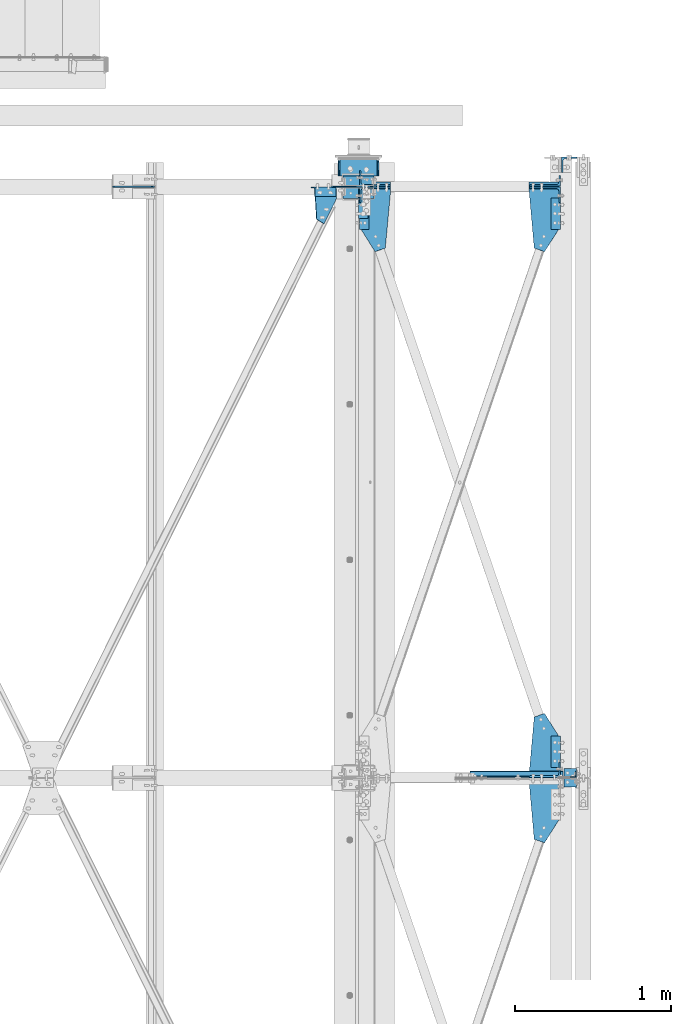
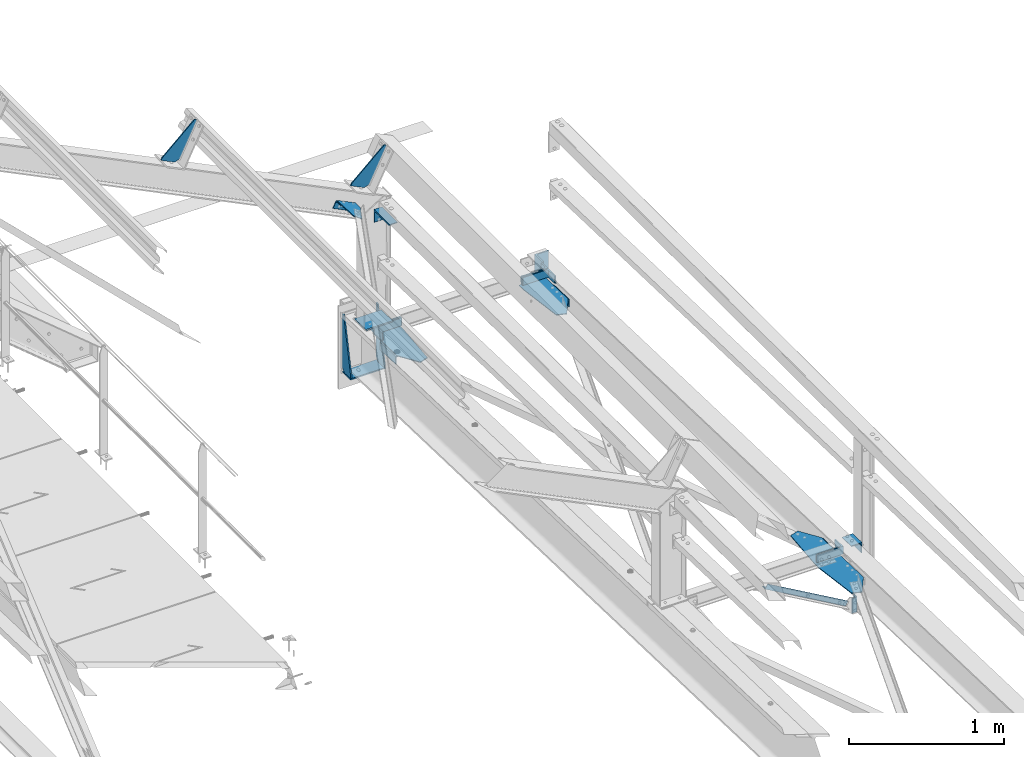
# One storey, part 112 of 496: 17 beams, 7 members, 22 elements without a shape of their own.
"""IFC2X3 building model written with IfcOpenShell, lengths in millimetres."""

from ifc_helpers import new_model, si_unit, frame, origin_with_axes, origin_2d_with_axis, place, context, subcontext, project, spatial, polyline, rectangle, l_section, outline, extrude, clip, halfspace, material, type_object, element, aggregate, save


model = new_model("IFC2X3")

# Units and contexts
model_context = context("Model", 3, precision=1e-05, world=origin_with_axes())
body_context = subcontext(model_context, "Body", "Model", "MODEL_VIEW")
ifc_project = project(units=[si_unit("LENGTHUNIT", "METRE", prefix="MILLI"), si_unit("AREAUNIT", "SQUARE_METRE"), si_unit("VOLUMEUNIT", "CUBIC_METRE"), si_unit("MASSUNIT", "GRAM", prefix="KILO"), si_unit("TIMEUNIT", "SECOND"), si_unit("PLANEANGLEUNIT", "RADIAN"), si_unit("SOLIDANGLEUNIT", "STERADIAN"), si_unit("THERMODYNAMICTEMPERATUREUNIT", "DEGREE_CELSIUS"), si_unit("LUMINOUSINTENSITYUNIT", "LUMEN")], contexts=[model_context])

# Site, building, storey
site_placement = place(None, origin_with_axes())
site = spatial("IfcSite", under=ifc_project, at=site_placement, CompositionType="ELEMENT")
building_placement = place(site_placement, origin_with_axes())
building = spatial("IfcBuilding", under=site, at=building_placement, Name="Undefined", CompositionType="ELEMENT")
storey_placement = place(building_placement, origin_with_axes())
storey = spatial("IfcBuildingStorey", under=building, at=storey_placement, Name="Undefined", CompositionType="ELEMENT", Elevation=0.0)

# Assembly, beam
assembly_1_placement = place(storey_placement, origin_with_axes())
assembly_1 = element("IfcElementAssembly", 1, at=assembly_1_placement, inside=storey, AssemblyPlace="NOTDEFINED", PredefinedType="NOTDEFINED")
ifc_material = material(Name="Undefined/S235-E24")
beam_type_1 = type_object("IfcBeamType", PredefinedType="NOTDEFINED")
beam_1_placement = place(assembly_1_placement, frame((39596.4999999987, 11466.9500236267, 7533.55960076532), z_axis=(0.0, -0.031410887010906, -0.999506556345274), x_axis=(0.0, 0.999506556345274, -0.0314108870109058)))
beam_1 = element("IfcBeam", 2, at=beam_1_placement, type_object=beam_type_1, material=ifc_material, context=body_context, shape_type="SweptSolid", body=[
    extrude(l_section(Depth=60.0, Width=60.0, Thickness=6.0, FilletRadius=8.0, EdgeRadius=4.0, at=origin_2d_with_axis()), frame((200.0, 0.0, 0.0), z_axis=(-1.0, 0.0, 0.0), x_axis=(0.0, -1.0, 0.0)), (0.0, 0.0, 1.0), 200.0),
])
aggregate(assembly_1, [beam_1])

assembly_2_placement = place(storey_placement, origin_with_axes())
assembly_2 = element("IfcElementAssembly", 3, at=assembly_2_placement, inside=storey, AssemblyPlace="NOTDEFINED", PredefinedType="NOTDEFINED")
beam_2_placement = place(assembly_2_placement, frame((39596.4999999987, 14925.2331446423, 7424.8786388297), z_axis=(0.0, -0.031410887010906, -0.999506556345274), x_axis=(0.0, 0.999506556345274, -0.0314108870109058)))
beam_2 = element("IfcBeam", 4, at=beam_2_placement, type_object=beam_type_1, material=ifc_material, context=body_context, shape_type="SweptSolid", body=[
    extrude(l_section(Depth=60.0, Width=60.0, Thickness=6.0, FilletRadius=8.0, EdgeRadius=4.0, at=origin_2d_with_axis()), frame((200.0, 0.0, 0.0), z_axis=(-1.0, 0.0, 0.0), x_axis=(0.0, -1.0, 0.0)), (0.0, 0.0, 1.0), 200.0),
])
aggregate(assembly_2, [beam_2])

assembly_3_placement = place(storey_placement, origin_with_axes())
assembly_3 = element("IfcElementAssembly", 5, at=assembly_3_placement, inside=storey, AssemblyPlace="NOTDEFINED", PredefinedType="NOTDEFINED")
beam_3_placement = place(assembly_3_placement, frame((38365.0000000024, 15125.1344555687, 7418.59645027728), z_axis=(0.0, -0.031410887010906, -0.999506556345274), x_axis=(0.0, -0.999506556345276, 0.031410887010852)))
beam_3 = element("IfcBeam", 6, at=beam_3_placement, type_object=beam_type_1, material=ifc_material, context=body_context, shape_type="SweptSolid", body=[
    extrude(l_section(Depth=60.0, Width=60.0, Thickness=6.0, FilletRadius=8.0, EdgeRadius=4.0, at=origin_2d_with_axis()), frame((200.0, 0.0, 0.0), z_axis=(-1.0, 0.0, 0.0), x_axis=(0.0, -1.0, 0.0)), (0.0, 0.0, 1.0), 200.0),
])
aggregate(assembly_3, [beam_3])

assembly_4_placement = place(storey_placement, origin_with_axes())
assembly_4 = element("IfcElementAssembly", 7, at=assembly_4_placement, inside=storey, Name="TRAVERSE SHED", AssemblyPlace="NOTDEFINED", PredefinedType="NOTDEFINED")
beam_type_2 = type_object("IfcBeamType", PredefinedType="NOTDEFINED")
beam_4_placement = place(assembly_4_placement, frame((38330.0, 15274.8056218445, 7574.97237948849), z_axis=(-1.0, 0.0, 0.0), x_axis=(0.0, -0.999506556345276, 0.031410887010852)))
beam_4 = element("IfcBeam", 8, at=beam_4_placement, type_object=beam_type_2, material=ifc_material, context=body_context, shape_type="SweptSolid", body=[
    extrude(rectangle(XDim=10.0, YDim=200.0, at=origin_2d_with_axis()), frame((149.999995982835, 4.54747350886464e-12, 3.63797880709171e-12), z_axis=(-1.0, 0.0, 0.0), x_axis=(0.0, -1.0, 0.0)), (0.0, 0.0, 1.0), 150.0),
])
aggregate(assembly_4, [beam_4])

assembly_5_placement = place(storey_placement, origin_with_axes())
assembly_5 = element("IfcElementAssembly", 9, at=assembly_5_placement, inside=storey, AssemblyPlace="NOTDEFINED", PredefinedType="NOTDEFINED")
beam_type_3 = type_object("IfcBeamType", PredefinedType="NOTDEFINED")
beam_5_placement = place(assembly_5_placement, frame((39689.0, 11460.1274473956, 7639.62620400558), z_axis=(-1.0, 0.0, 0.0), x_axis=(0.0, -0.999506556345276, 0.031410887010852)))
beam_5 = element("IfcBeam", 10, at=beam_5_placement, type_object=beam_type_3, material=ifc_material, context=body_context, shape_type="SweptSolid", body=[
    extrude(l_section(Depth=80.0, Width=80.0, Thickness=8.0, FilletRadius=10.0, EdgeRadius=5.0, at=origin_2d_with_axis()), frame((120.0, 0.0, 0.0), z_axis=(-1.0, 0.0, 0.0), x_axis=(0.0, -1.0, 0.0)), (0.0, 0.0, 1.0), 120.0),
])
aggregate(assembly_5, [beam_5])

assembly_6_placement = place(storey_placement, origin_with_axes())
assembly_6 = element("IfcElementAssembly", 11, at=assembly_6_placement, inside=storey, AssemblyPlace="NOTDEFINED", PredefinedType="NOTDEFINED")
beam_type_4 = type_object("IfcBeamType", PredefinedType="NOTDEFINED")
beam_6_placement = place(assembly_6_placement, frame((39709.0000003665, 11422.9999999731, 7220.00000925125), z_axis=(-1.0, 0.0, 0.0), x_axis=(0.0, 0.0, -1.0)))
beam_6 = element("IfcBeam", 12, at=beam_6_placement, type_object=beam_type_4, material=ifc_material, context=body_context, shape_type="SweptSolid", body=[
    extrude(l_section(Depth=40.0, Width=40.0, Thickness=4.0, FilletRadius=6.0, EdgeRadius=3.0, at=origin_2d_with_axis()), frame((120.0, 0.0, 0.0), z_axis=(-1.0, 0.0, 0.0), x_axis=(0.0, -1.0, 0.0)), (0.0, 0.0, 1.0), 120.0),
])
aggregate(assembly_6, [beam_6])

# Assembly, member
assembly_7_placement = place(storey_placement, origin_with_axes())
assembly_7 = element("IfcElementAssembly", 13, at=assembly_7_placement, inside=storey, AssemblyPlace="NOTDEFINED", PredefinedType="NOTDEFINED")
member_type_1 = type_object("IfcMemberType", PredefinedType="NOTDEFINED")
member_1_placement = place(assembly_7_placement, frame((38035.9184902341, 15167.0004847153, 8592.20874332605), z_axis=(0.0, -1.0, 0.0), x_axis=(0.897398510539058, 0.0, -0.441220934773362)))
member_1 = element("IfcMember", 14, at=member_1_placement, type_object=member_type_1, material=ifc_material, context=body_context, shape_type="SweptSolid", body=[
    extrude(l_section(Depth=60.0, Width=60.0, Thickness=6.0, FilletRadius=8.0, EdgeRadius=4.0, at=origin_2d_with_axis()), frame((149.999995982835, 4.54747350886464e-12, 3.63797880709171e-12), z_axis=(-1.0, 0.0, 0.0), x_axis=(0.0, -1.0, 0.0)), (0.0, 0.0, 1.0), 150.0),
])
aggregate(assembly_7, [member_1])

# Assembly, beam
assembly_8_placement = place(storey_placement, origin_with_axes())
assembly_8 = element("IfcElementAssembly", 15, at=assembly_8_placement, inside=storey, Name="SHED", AssemblyPlace="NOTDEFINED", PredefinedType="NOTDEFINED")
beam_type_5 = type_object("IfcBeamType", PredefinedType="NOTDEFINED")
beam_7_placement = place(assembly_8_placement, frame((38167.3881652729, 15200.0, 8712.54750741415), z_axis=(0.0, -1.0, 0.0), x_axis=(-0.441220935974661, 0.0, -0.89739850994842)))
beam_7 = element("IfcBeam", 16, at=beam_7_placement, type_object=beam_type_5, material=ifc_material, context=body_context, shape_type="SweptSolid", body=[
    extrude(outline(polyline([(0.0, 0.0), (20.0, 0.0), (20.0000000002019, 109.999999999982), (-9.99999999974731, 139.99998998623), (-300.0000000002, 139.999893186625), (-300.000000000226, 119.999893186643), (0.0, 0.0)])), frame((0.0, 0.0, -4.0), z_axis=(0.0, 0.0, 1.0), x_axis=(1.0, 0.0, 0.0)), (0.0, 0.0, 1.0), 8.0),
])
aggregate(assembly_8, [beam_7])

assembly_9_placement = place(storey_placement, origin_with_axes())
assembly_9 = element("IfcElementAssembly", 17, at=assembly_9_placement, inside=storey, Name="SHED", AssemblyPlace="NOTDEFINED", PredefinedType="NOTDEFINED")
beam_8_placement = place(assembly_9_placement, frame((36758.937741054, 15200.0, 9405.03563331224), z_axis=(0.0, -1.0, 0.0), x_axis=(-0.441220935974661, 0.0, -0.89739850994842)))
beam_8 = element("IfcBeam", 18, at=beam_8_placement, type_object=beam_type_5, material=ifc_material, context=body_context, shape_type="SweptSolid", body=[
    extrude(outline(polyline([(0.0, 0.0), (20.0, 0.0), (20.0000000002019, 109.999999999982), (-9.99999999974731, 139.99998998623), (-300.0000000002, 139.999893186625), (-300.000000000226, 119.999893186643), (0.0, 0.0)])), frame((0.0, 0.0, -4.0), z_axis=(0.0, 0.0, 1.0), x_axis=(1.0, 0.0, 0.0)), (0.0, 0.0, 1.0), 8.0),
])
aggregate(assembly_9, [beam_8])

# Assembly, member
assembly_10_placement = place(storey_placement, origin_with_axes())
assembly_10 = element("IfcElementAssembly", 19, at=assembly_10_placement, inside=storey, AssemblyPlace="NOTDEFINED", PredefinedType="NOTDEFINED")
member_type_2 = type_object("IfcMemberType", PredefinedType="NOTDEFINED")
member_2_placement = place(assembly_10_placement, frame((39526.5, 15253.6029386135, 7530.61641099022), z_axis=(-1.0, 0.0, 0.0), x_axis=(0.0, -0.031410887010906, -0.999506556345274)))
member_2 = element("IfcMember", 20, at=member_2_placement, type_object=member_type_2, material=ifc_material, context=body_context, shape_type="Clipping", body=[
    clip(extrude(l_section(Depth=200.0, Width=100.0, Thickness=10.0, FilletRadius=15.0, EdgeRadius=7.5, at=origin_2d_with_axis()), frame((60.0, 0.0, 0.0), z_axis=(-1.0, 0.0, 0.0), x_axis=(0.0, -1.0, 0.0)), (0.0, 0.0, 1.0), 60.0), halfspace(frame((1.72803993336856e-11, -19.9999999480369, -100.0), z_axis=(0.0, -1.0, 0.0), x_axis=(0.0, 0.0, 1.0)), False)),
])
aggregate(assembly_10, [member_2])

assembly_11_placement = place(storey_placement, origin_with_axes())
assembly_11 = element("IfcElementAssembly", 21, at=assembly_11_placement, inside=storey, AssemblyPlace="NOTDEFINED", PredefinedType="NOTDEFINED")
member_3_placement = place(assembly_11_placement, frame((39526.4999999999, 15145.7696877701, 7473.97567400464), z_axis=(-1.0, 0.0, 0.0), x_axis=(0.0, 0.031410887010906, 0.999506556345274)))
member_3 = element("IfcMember", 22, at=member_3_placement, type_object=member_type_2, material=ifc_material, context=body_context, shape_type="SweptSolid", body=[
    extrude(l_section(Depth=200.0, Width=100.0, Thickness=10.0, FilletRadius=15.0, EdgeRadius=7.5, at=origin_2d_with_axis()), frame((60.0, 0.0, 0.0), z_axis=(-1.0, 0.0, 0.0), x_axis=(0.0, -1.0, 0.0)), (0.0, 0.0, 1.0), 60.0),
])
aggregate(assembly_11, [member_3])

assembly_12_placement = place(storey_placement, origin_with_axes())
assembly_12 = element("IfcElementAssembly", 23, at=assembly_12_placement, inside=storey, AssemblyPlace="NOTDEFINED", PredefinedType="NOTDEFINED")
member_4_placement = place(assembly_12_placement, frame((39526.5, 11453.6029378067, 7650.03622172562), z_axis=(-1.0, 0.0, 0.0), x_axis=(0.0, -0.031410887010906, -0.999506556345274)))
member_4 = element("IfcMember", 24, at=member_4_placement, type_object=member_type_2, material=ifc_material, context=body_context, shape_type="SweptSolid", body=[
    extrude(l_section(Depth=200.0, Width=100.0, Thickness=10.0, FilletRadius=15.0, EdgeRadius=7.5, at=origin_2d_with_axis()), frame((60.0, 0.0, 0.0), z_axis=(-1.0, 0.0, 0.0), x_axis=(0.0, -1.0, 0.0)), (0.0, 0.0, 1.0), 60.0),
])
aggregate(assembly_12, [member_4])

assembly_13_placement = place(storey_placement, origin_with_axes())
assembly_13 = element("IfcElementAssembly", 25, at=assembly_13_placement, inside=storey, AssemblyPlace="NOTDEFINED", PredefinedType="NOTDEFINED")
member_5_placement = place(assembly_13_placement, frame((38435.0, 15251.7182422282, 7470.64601896635), z_axis=(1.0, 0.0, 0.0), x_axis=(0.0, 0.031410887010906, 0.999506556345274)))
member_5 = element("IfcMember", 26, at=member_5_placement, type_object=member_type_2, material=ifc_material, context=body_context, shape_type="SweptSolid", body=[
    extrude(l_section(Depth=200.0, Width=100.0, Thickness=10.0, FilletRadius=15.0, EdgeRadius=7.5, at=origin_2d_with_axis()), frame((60.0, 0.0, 0.0), z_axis=(-1.0, 0.0, 0.0), x_axis=(0.0, -1.0, 0.0)), (0.0, 0.0, 1.0), 60.0),
])
aggregate(assembly_13, [member_5])

assembly_14_placement = place(storey_placement, origin_with_axes())
assembly_14 = element("IfcElementAssembly", 27, at=assembly_14_placement, inside=storey, AssemblyPlace="NOTDEFINED", PredefinedType="NOTDEFINED")
member_6_placement = place(assembly_14_placement, frame((38435.0000000001, 15147.6543841035, 7533.94606602883), z_axis=(1.0, 0.0, 0.0), x_axis=(0.0, -0.031410887010906, -0.999506556345274)))
member_6 = element("IfcMember", 28, at=member_6_placement, type_object=member_type_2, material=ifc_material, context=body_context, shape_type="SweptSolid", body=[
    extrude(l_section(Depth=200.0, Width=100.0, Thickness=10.0, FilletRadius=15.0, EdgeRadius=7.5, at=origin_2d_with_axis()), frame((60.0, 0.0, 0.0), z_axis=(-1.0, 0.0, 0.0), x_axis=(0.0, -1.0, 0.0)), (0.0, 0.0, 1.0), 60.0),
])
aggregate(assembly_14, [member_6])

# Assembly, beam
assembly_15_placement = place(storey_placement, origin_with_axes())
assembly_15 = element("IfcElementAssembly", 29, at=assembly_15_placement, inside=storey, AssemblyPlace="NOTDEFINED", PredefinedType="NOTDEFINED")
beam_type_6 = type_object("IfcBeamType", PredefinedType="NOTDEFINED")
beam_9_placement = place(assembly_15_placement, frame((38330.0, 15096.5, 8400.0), z_axis=(0.0, -1.0, 0.0), x_axis=(1.0, 0.0, 0.0)))
beam_9 = element("IfcBeam", 30, at=beam_9_placement, type_object=beam_type_6, material=ifc_material, context=body_context, shape_type="SweptSolid", body=[
    extrude(l_section(Depth=200.0, Width=100.0, Thickness=10.0, FilletRadius=15.0, EdgeRadius=7.5, at=origin_2d_with_axis()), frame((60.0, 0.0, 0.0), z_axis=(-1.0, 0.0, 0.0), x_axis=(0.0, -1.0, 0.0)), (0.0, 0.0, 1.0), 60.0),
])
aggregate(assembly_15, [beam_9])

assembly_16_placement = place(storey_placement, origin_with_axes())
assembly_16 = element("IfcElementAssembly", 31, at=assembly_16_placement, inside=storey, AssemblyPlace="NOTDEFINED", PredefinedType="NOTDEFINED")
beam_type_7 = type_object("IfcBeamType", PredefinedType="NOTDEFINED")
beam_10_placement = place(assembly_16_placement, frame((38059.1846576872, 14990.7417709219, 8617.54258339522), z_axis=(0.441221071222121, 0.0, 0.897398443451739), x_axis=(0.784869567232957, -0.48483568373157, -0.385893926114537)))
beam_10 = element("IfcBeam", 32, at=beam_10_placement, type_object=beam_type_7, material=ifc_material, context=body_context, shape_type="SweptSolid", body=[
    extrude(outline(polyline([(0.0, 0.0), (60.0, 0.0), (60.000000001357, 181.13842773447), (27.5527534497232, 239.6707305907), (-103.638031004382, 166.945343016534), (-79.3962478622052, 123.215103148526), (0.0, 0.0)])), frame((0.0, 0.0, -3.0), z_axis=(0.0, 0.0, 1.0), x_axis=(1.0, 0.0, 0.0)), (0.0, 0.0, 1.0), 6.0),
])
aggregate(assembly_16, [beam_10])

assembly_17_placement = place(storey_placement, origin_with_axes())
assembly_17 = element("IfcElementAssembly", 33, at=assembly_17_placement, inside=storey, AssemblyPlace="NOTDEFINED", PredefinedType="NOTDEFINED")
beam_type_8 = type_object("IfcBeamType", PredefinedType="NOTDEFINED")
beam_11_placement = place(assembly_17_placement, frame((39426.5000021693, 15166.0369146745, 7450.32736574131), z_axis=(0.0, 0.031410887010906, 0.999506556345274), x_axis=(0.088182195981499, -0.995612844791183, 0.0312883939934374)))
beam_11 = element("IfcBeam", 34, at=beam_11_placement, type_object=beam_type_8, material=ifc_material, context=body_context, shape_type="SweptSolid", body=[
    extrude(outline(polyline([(0.0, 0.0), (362.811950685289, 3.18686943501234e-09), (391.212585451196, 63.9797134429609), (255.705718996318, 168.106185915145), (-46.9960632305665, 194.903488158983), (-63.7506790149928, 5.6436605449635), (0.0, 0.0)])), frame((0.0, 0.0, -3.0), z_axis=(0.0, 0.0, 1.0), x_axis=(1.0, 0.0, 0.0)), (0.0, 0.0, 1.0), 6.0),
])
aggregate(assembly_17, [beam_11])

assembly_18_placement = place(storey_placement, origin_with_axes())
assembly_18 = element("IfcElementAssembly", 35, at=assembly_18_placement, inside=storey, AssemblyPlace="NOTDEFINED", PredefinedType="NOTDEFINED")
beam_12_placement = place(assembly_18_placement, frame((39616.4999999994, 11667.8878950366, 7560.26112725823), z_axis=(0.0, 0.031410887010906, 0.999506556345274), x_axis=(-0.532055580969613, 0.846291629951644, -0.0265957859984812)))
beam_12 = element("IfcBeam", 36, at=beam_12_placement, type_object=beam_type_8, material=ifc_material, context=body_context, shape_type="SweptSolid", body=[
    extrude(outline(polyline([(0.0, 0.0), (172.484863279265, 3.49245965480804e-10), (188.549133298598, 68.1317825326551), (-100.426284790734, 287.503997807151), (-154.615692139079, 321.555572514764), (-477.637298582615, 486.750213630985), (-532.054260252127, 442.71856690212), (-457.215545652767, 287.305267339485), (0.0, 0.0)])), frame((0.0, 0.0, -3.0), z_axis=(0.0, 0.0, 1.0), x_axis=(1.0, 0.0, 0.0)), (0.0, 0.0, 1.0), 6.0),
])
aggregate(assembly_18, [beam_12])

assembly_19_placement = place(storey_placement, origin_with_axes())
assembly_19 = element("IfcElementAssembly", 37, at=assembly_19_placement, inside=storey, AssemblyPlace="NOTDEFINED", PredefinedType="NOTDEFINED")
beam_13_placement = place(assembly_19_placement, frame((38535.0, 15166.0369146996, 7450.32736574171), z_axis=(0.0, 0.031410887010906, 0.999506556345274), x_axis=(0.0, 0.999506556345274, -0.0314108870109058)))
beam_13 = element("IfcBeam", 38, at=beam_13_placement, type_object=beam_type_8, material=ifc_material, context=body_context, shape_type="SweptSolid", body=[
    extrude(outline(polyline([(0.0, 0.0), (63.9999999997126, 1.45519152283669e-11), (63.999999999709, 190.0), (-239.88557433976, 190.0), (-384.046691892825, 99.7284622192383), (-361.398559568706, 33.4935569763184), (0.0, 0.0)])), frame((0.0, 0.0, -3.0), z_axis=(0.0, 0.0, 1.0), x_axis=(1.0, 0.0, 0.0)), (0.0, 0.0, 1.0), 6.0),
])
aggregate(assembly_19, [beam_13])

assembly_20_placement = place(storey_placement, origin_with_axes())
assembly_20 = element("IfcElementAssembly", 39, at=assembly_20_placement, inside=storey, AssemblyPlace="NOTDEFINED", PredefinedType="NOTDEFINED")
beam_type_9 = type_object("IfcBeamType", PredefinedType="NOTDEFINED")
beam_14_placement = place(assembly_20_placement, frame((39684.9999999956, 15339.9999930777, 7523.32582689857), z_axis=(1.0, 0.0, 0.0), x_axis=(0.0, 0.0, -1.0)))
beam_14 = element("IfcBeam", 40, at=beam_14_placement, type_object=beam_type_9, material=ifc_material, context=body_context, shape_type="SweptSolid", body=[
    extrude(l_section(Depth=100.0, Width=100.0, Thickness=10.0, FilletRadius=12.0, EdgeRadius=6.0, at=origin_2d_with_axis()), frame((180.0, 0.0, 0.0), z_axis=(-1.0, 0.0, 0.0), x_axis=(0.0, -1.0, 0.0)), (0.0, 0.0, 1.0), 180.0),
])
aggregate(assembly_20, [beam_14])

# Assembly, member
assembly_21_placement = place(storey_placement, origin_with_axes())
assembly_21 = element("IfcElementAssembly", 41, at=assembly_21_placement, inside=storey, AssemblyPlace="NOTDEFINED", PredefinedType="NOTDEFINED")
member_type_3 = type_object("IfcMemberType", PredefinedType="NOTDEFINED")
member_7_placement = place(assembly_21_placement, frame((39728.0037125785, 11423.0003840832, 7148.26582035652), z_axis=(0.49814372323054, 0.0, 0.867094476401514), x_axis=(-0.867094476401514, 0.0, 0.498143723230539)))
member_7 = element("IfcMember", 42, at=member_7_placement, type_object=member_type_3, material=ifc_material, context=body_context, shape_type="Clipping", body=[
    clip(clip(extrude(l_section(Depth=40.0, Width=40.0, Thickness=4.0, FilletRadius=6.0, EdgeRadius=3.0, at=origin_2d_with_axis()), frame((811.405783381609, 1.81898940354586e-12, 0.0), z_axis=(-1.0, 0.0, 0.0), x_axis=(0.0, -1.0, 0.0)), (0.0, 0.0, 1.0), 758.69), halfspace(frame((776.505219575367, 23.0003841101498, 20.0000002380839), z_axis=(-1.0, 0.0, 0.0), x_axis=(0.0, -1.0, 0.0)), True)), halfspace(frame((87.6210270062365, 23.0003841101498, 20.0000002380802), z_axis=(-1.0, 0.0, 0.0), x_axis=(0.0, -1.0, 0.0)), False)),
])
aggregate(assembly_21, [member_7])

# Assembly, beams
assembly_22_placement = place(storey_placement, origin_with_axes())
assembly_22 = element("IfcElementAssembly", 43, at=assembly_22_placement, inside=storey, AssemblyPlace="NOTDEFINED", PredefinedType="NOTDEFINED")
beam_type_10 = type_object("IfcBeamType", PredefinedType="NOTDEFINED")
beam_15_placement = place(assembly_22_placement, frame((38205.000000001, 15270.0420944345, 7119.8974601232), z_axis=(-1.0, 0.0, 0.0), x_axis=(0.0, 0.031410887010906, 0.999506556345274)))
beam_15 = element("IfcBeam", 44, at=beam_15_placement, type_object=beam_type_10, material=ifc_material, context=body_context, shape_type="SweptSolid", body=[
    extrude(outline(polyline([(0.0, 0.0), (20.0, 0.0), (447.705322266376, 75.9325637814163), (448.333496094502, 95.9226913448147), (29.9851968664639, 109.069869088122), (3.83439057142213e-08, 80.0121917722809), (0.0, 0.0)])), frame((0.0, 0.0, -5.0), z_axis=(0.0, 0.0, 1.0), x_axis=(1.0, 0.0, 0.0)), (0.0, 0.0, 1.0), 10.0),
])
beam_16_placement = place(assembly_22_placement, frame((38454.9999999928, 15270.0420944364, 7119.89746012322), z_axis=(-1.0, 0.0, 0.0), x_axis=(0.0, 0.031410887010906, 0.999506556345274)))
beam_16 = element("IfcBeam", 45, at=beam_16_placement, type_object=beam_type_10, material=ifc_material, context=body_context, shape_type="SweptSolid", body=[
    extrude(outline(polyline([(0.0, 0.0), (20.0, 0.0), (447.705322266376, 75.9325637814163), (448.333496094502, 95.9226913448147), (29.9851968664639, 109.069869088122), (3.83439057142213e-08, 80.0121917722809), (0.0, 0.0)])), frame((0.0, 0.0, -5.0), z_axis=(0.0, 0.0, 1.0), x_axis=(1.0, 0.0, 0.0)), (0.0, 0.0, 1.0), 10.0),
])
beam_type_11 = type_object("IfcBeamType", PredefinedType="NOTDEFINED")
beam_17_placement = place(assembly_22_placement, frame((38329.9999999995, 15379.8429460911, 7111.44434761663), z_axis=(-1.0, 0.0, 0.0), x_axis=(0.0, -0.999506556345276, 0.031410887010852)))
beam_17 = element("IfcBeam", 46, at=beam_17_placement, type_object=beam_type_11, material=ifc_material, context=body_context, shape_type="SweptSolid", body=[
    extrude(rectangle(XDim=10.0, YDim=260.0, at=origin_2d_with_axis()), frame((110.012190922962, 0.0, 0.0), z_axis=(-1.0, 0.0, 0.0), x_axis=(0.0, -1.0, 0.0)), (0.0, 0.0, 1.0), 110.01),
])
aggregate(assembly_22, [beam_15, beam_16, beam_17])

save(model, "model.ifc")
